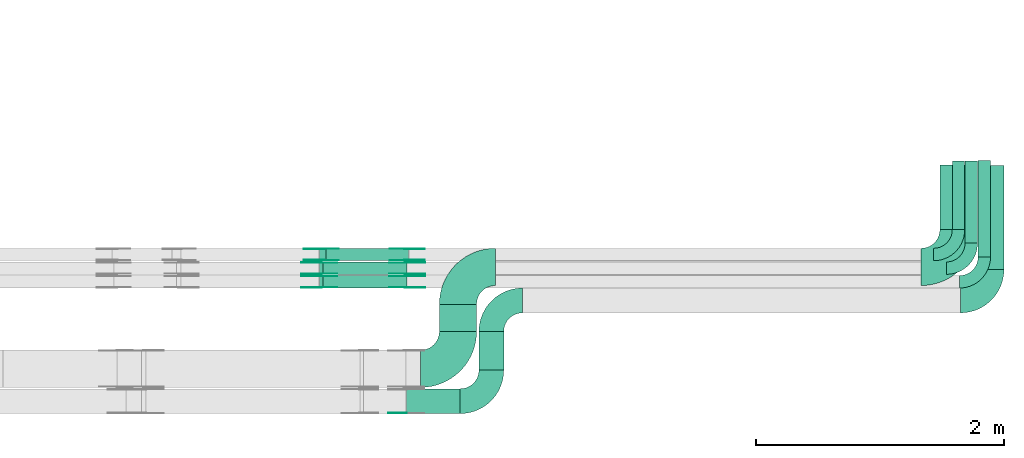
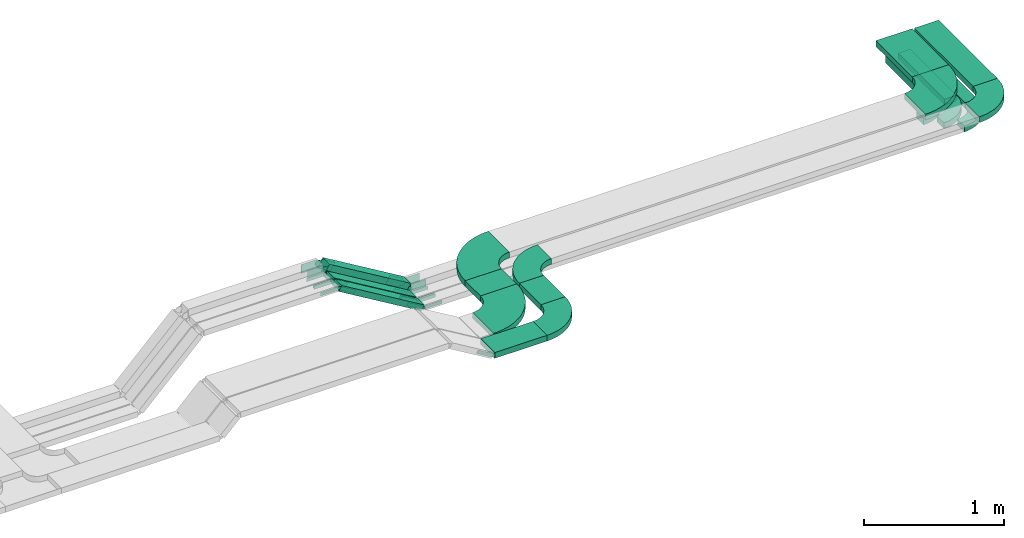
# One storey, part 18 of 19: 34 flow fittings, 11 flow segments.
"""IFC2X3 building model written with IfcOpenShell, lengths in millimetres."""

import ifcopenshell
import ifcopenshell.guid

model = None  # the IFC model being written
_history = None  # IfcOwnerHistory: only IFC2X3 demands one
_inside = {}  # id of a spatial element -> (the spatial element, [elements in it])
_under = {}  # id of a project, library or spatial element -> (it, [spatial elements below it])
_declared = {}  # id of a project -> (the project, [libraries it declares])
_typed = {}  # id of a type object -> (the type object, [elements of that type])
_made_of = {}  # id of a material, layer set ... -> (it, [elements and type objects made of it])


def new_model(schema):
    """Start an empty IFC model of exactly this schema.

    Asked for "IFC4X3", IfcOpenShell would pick the latest addendum, in which some entities
    have other attributes; the version numbers below select the first issue.
    IFC2X3 requires an IfcOwnerHistory on every rooted entity: one is made here for all.
    """
    global model, _history
    if schema == "IFC4X3":
        model = ifcopenshell.file(schema_version=(4, 3, 0, 0))
    else:
        model = ifcopenshell.file(schema=schema)
    _inside.clear()
    _under.clear()
    _declared.clear()
    _typed.clear()
    _made_of.clear()
    _history = None
    if model.schema == "IFC2X3":
        org = make("IfcOrganization", Name="unknown")
        user = make(
            "IfcPersonAndOrganization",
            ThePerson=make("IfcPerson", FamilyName="unknown"),
            TheOrganization=org,
        )
        app = make(
            "IfcApplication",
            ApplicationDeveloper=org,
            Version="unknown",
            ApplicationFullName="unknown",
            ApplicationIdentifier="unknown",
        )
        _history = make(
            "IfcOwnerHistory",
            OwningUser=user,
            OwningApplication=app,
            ChangeAction="ADDED",
            CreationDate=0,
        )
    return model


def make(cls, **values):
    """One entity of the class cls with the attributes given. An attribute that is None is left unset."""
    return model.create_entity(
        cls, **{name: value for name, value in values.items() if value is not None}
    )


def entity(cls, *values):
    """Any entity or typed value of the class cls, its attributes in the order of the schema. None: left unset."""
    e = model.create_entity(cls)
    for i, value in enumerate(values):
        if value is not None:
            e[i] = value
    return e


def rooted(cls, **values):
    """An entity with a GlobalId (a new one), such as an element, a storey or a relation."""
    return make(cls, GlobalId=ifcopenshell.guid.new(), OwnerHistory=_history, **values)


def si_unit(unit_type, name, prefix=None):
    """IfcSIUnit, for example si_unit("LENGTHUNIT", "METRE", prefix="MILLI")."""
    return make("IfcSIUnit", UnitType=unit_type, Prefix=prefix, Name=name)


def converted_unit(unit_type, name, factor, base, dimensions=None, offset=None):
    """IfcConversionBasedUnit, such as the inch: factor (a typed value) times the base unit."""
    return make(
        "IfcConversionBasedUnit"
        if offset is None
        else "IfcConversionBasedUnitWithOffset",
        ConversionOffset=offset,
        Dimensions=None
        if dimensions is None
        else entity("IfcDimensionalExponents", *dimensions),
        UnitType=unit_type,
        Name=name,
        ConversionFactor=make(
            "IfcMeasureWithUnit", ValueComponent=factor, UnitComponent=base
        ),
    )


def derived_unit(unit_type, elements):
    """IfcDerivedUnit: a product of units, each with its exponent."""
    return make(
        "IfcDerivedUnit",
        Elements=[
            make("IfcDerivedUnitElement", Unit=unit, Exponent=power)
            for unit, power in elements
        ],
        UnitType=unit_type,
    )


def assignment(units):
    """IfcUnitAssignment: the units of a project."""
    return None if units is None else make("IfcUnitAssignment", Units=units)


def point(xyz):
    """IfcCartesianPoint."""
    return None if xyz is None else make("IfcCartesianPoint", Coordinates=xyz)


def direction(xyz):
    """IfcDirection."""
    return None if xyz is None else make("IfcDirection", DirectionRatios=xyz)


def frame(location, z_axis=None, x_axis=None):
    """IfcAxis2Placement3D, a coordinate frame: its origin and axes. An axis left out is left unset."""
    return make(
        "IfcAxis2Placement3D",
        Location=point(location),
        Axis=direction(z_axis),
        RefDirection=direction(x_axis),
    )


def frame_2d(location, x_axis=None):
    """IfcAxis2Placement2D, a coordinate frame in the plane: its origin and x axis."""
    return make(
        "IfcAxis2Placement2D", Location=point(location), RefDirection=direction(x_axis)
    )


def origin():
    """The frame at (0, 0, 0) with its axes left unset."""
    return frame((0.0, 0.0, 0.0))


def origin_2d_with_axis():
    """The frame at (0, 0) in the plane with the x axis (1, 0) written out."""
    return frame_2d((0.0, 0.0), x_axis=(1.0, 0.0))


def place(relative_to, where):
    """IfcLocalPlacement: puts the frame where relative to a parent placement (None: the world)."""
    return make(
        "IfcLocalPlacement", PlacementRelTo=relative_to, RelativePlacement=where
    )


def context(
    kind, dimensions, precision=None, world=None, true_north=None, identifier=None
):
    """IfcGeometricRepresentationContext, for example the 3D "Model" context."""
    return make(
        "IfcGeometricRepresentationContext",
        ContextIdentifier=identifier,
        ContextType=kind,
        CoordinateSpaceDimension=dimensions,
        Precision=precision,
        WorldCoordinateSystem=world,
        TrueNorth=true_north,
    )


def subcontext(parent, identifier, kind, view, scale=None):
    """IfcGeometricRepresentationSubContext, for example "Body" below "Model"."""
    return make(
        "IfcGeometricRepresentationSubContext",
        ContextIdentifier=identifier,
        ContextType=kind,
        ParentContext=parent,
        TargetScale=scale,
        TargetView=view,
    )


def project(units=None, contexts=None):
    """IfcProject with its units and contexts."""
    return rooted(
        "IfcProject",
        Name="project",
        RepresentationContexts=contexts,
        UnitsInContext=assignment(units),
    )


def spatial(cls, under=None, at=None, **own):
    """A site, building, storey or space (cls), placed at a placement, below another one or the project."""
    s = rooted(cls, ObjectPlacement=at, **own)
    if under is not None:
        _under.setdefault(under.id(), (under, []))[1].append(s)
    return s


def polyline(points):
    """IfcPolyline through the points."""
    return make("IfcPolyline", Points=[point(p) for p in points])


def circle_curve(where, radius):
    """IfcCircle in the frame where."""
    return make("IfcCircle", Position=where, Radius=radius)


def parameter(value):
    """IfcParameterValue: where a trimmed curve begins or ends, as a parameter of its basis curve."""
    return model.create_entity("IfcParameterValue", value)


def trimmed(basis, trim1, trim2, sense, master):
    """IfcTrimmedCurve: the piece of a basis curve between two trims."""
    return make(
        "IfcTrimmedCurve",
        BasisCurve=basis,
        Trim1=trim1,
        Trim2=trim2,
        SenseAgreement=sense,
        MasterRepresentation=master,
    )


def segment(curve, same_sense, transition):
    """IfcCompositeCurveSegment."""
    return make(
        "IfcCompositeCurveSegment",
        Transition=transition,
        SameSense=same_sense,
        ParentCurve=curve,
    )


def composite_curve(segments, self_intersect=None):
    """IfcCompositeCurve: segments joined end to end."""
    return make("IfcCompositeCurve", Segments=segments, SelfIntersect=self_intersect)


def profile(cls, at=None, kind="AREA", **sizes):
    """A parametric profile (cls). Its sizes go by their IFC names, for example OverallWidth=200.0."""
    return make(cls, ProfileType=kind, Position=at, **sizes)


def rectangle(**sizes):
    """IfcRectangleProfileDef."""
    return profile("IfcRectangleProfileDef", **sizes)


def outline(outer, holes=None, kind="AREA"):
    """IfcArbitraryClosedProfileDef: a profile drawn as a closed curve; with holes, ...WithVoids."""
    if holes is None:
        return make("IfcArbitraryClosedProfileDef", ProfileType=kind, OuterCurve=outer)
    return make(
        "IfcArbitraryProfileDefWithVoids",
        ProfileType=kind,
        OuterCurve=outer,
        InnerCurves=holes,
    )


def extrude(swept, where, along, depth):
    """IfcExtrudedAreaSolid: the profile swept, set in the frame where, extruded along a direction by depth."""
    return make(
        "IfcExtrudedAreaSolid",
        SweptArea=swept,
        Position=where,
        ExtrudedDirection=direction(along),
        Depth=depth,
    )


def shape(context_of_items, identifier, shape_type, items):
    """IfcShapeRepresentation: the items that make up one representation, for example the "Body"."""
    return make(
        "IfcShapeRepresentation",
        ContextOfItems=context_of_items,
        RepresentationIdentifier=identifier,
        RepresentationType=shape_type,
        Items=items,
    )


def source(mapping_origin, context_of_items, identifier, shape_type, items):
    """IfcRepresentationMap: a shape defined once, which mapped items show again and again."""
    return make(
        "IfcRepresentationMap",
        MappingOrigin=mapping_origin,
        MappedRepresentation=shape(context_of_items, identifier, shape_type, items),
    )


def transform(
    local_origin,
    x_axis=None,
    y_axis=None,
    z_axis=None,
    scale=None,
    scale2=None,
    scale3=None,
    uniform=True,
):
    """IfcCartesianTransformationOperator3D, or its non-uniform kind. x_axis, y_axis, z_axis: its Axis1, 2, 3."""
    if uniform:
        return make(
            "IfcCartesianTransformationOperator3D",
            Axis1=direction(x_axis),
            Axis2=direction(y_axis),
            LocalOrigin=point(local_origin),
            Scale=scale,
            Axis3=direction(z_axis),
        )
    return make(
        "IfcCartesianTransformationOperator3DnonUniform",
        Axis1=direction(x_axis),
        Axis2=direction(y_axis),
        LocalOrigin=point(local_origin),
        Scale=scale,
        Axis3=direction(z_axis),
        Scale2=scale2,
        Scale3=scale3,
    )


def mapped(mapping_source, mapping_target):
    """IfcMappedItem: shows the shape of a source again, moved by a transform."""
    return make(
        "IfcMappedItem", MappingSource=mapping_source, MappingTarget=mapping_target
    )


def material(Name=None, Category=None):
    """IfcMaterial."""
    return make("IfcMaterial", Name=Name, Category=Category)


def made_of(thing, what):
    """Note that an element or type object is made of a material, layer set ...; save() writes the relation."""
    if what is not None:
        _made_of.setdefault(what.id(), (what, []))[1].append(thing)
    return thing


def type_object(cls, material=None, **own):
    """A type object (cls), such as IfcWallType, which elements share."""
    return made_of(rooted(cls, **own), material)


def type_shapes(of_type, sources):
    """Give a type object the sources (RepresentationMaps) that its elements show as mapped items."""
    of_type.RepresentationMaps = sources


def element(
    cls,
    number,
    at=None,
    inside=None,
    cuts=None,
    type_object=None,
    material=None,
    context=None,
    identifier="Body",
    shape_type=None,
    held_by="IfcProductDefinitionShape",
    body=None,
    shapes=None,
    **own,
):
    """One element of the class cls, such as IfcWall. Its Tag is "e" and its number.

    at: its placement. inside: the storey or other place that contains it. cuts: it is an
    opening in that element (IfcRelVoidsElement). A single representation is given by context,
    identifier, shape_type and body (its items); several are given by shapes. held_by: the class
    of the entity that holds the representations. save() writes the other relations.
    """
    e = rooted(cls, Tag="e%d" % number, ObjectPlacement=at, **own)
    if body is not None:
        shapes = [shape(context, identifier, shape_type, body)]
    if shapes is not None:
        e.Representation = make(held_by, Representations=shapes)
    if inside is not None:
        _inside.setdefault(inside.id(), (inside, []))[1].append(e)
    if cuts is not None:
        rooted(
            "IfcRelVoidsElement", RelatingBuildingElement=cuts, RelatedOpeningElement=e
        )
    if type_object is not None:
        _typed.setdefault(type_object.id(), (type_object, []))[1].append(e)
    return made_of(e, material)


def aggregate(whole, parts):
    """IfcRelAggregates: a whole, such as a stair, and the parts it consists of."""
    return rooted("IfcRelAggregates", RelatingObject=whole, RelatedObjects=parts)


def save(model, path):
    """Write the relations noted so far, then the file.

    IfcRelAggregates (storeys below a building ...), IfcRelContainedInSpatialStructure (elements
    in a storey), IfcRelDefinesByType, IfcRelAssociatesMaterial and IfcRelDeclares: one each for
    every whole, place, type object, material and project.
    """
    for whole, parts in _under.values():
        aggregate(whole, parts)
    for where, things in _inside.values():
        rooted(
            "IfcRelContainedInSpatialStructure",
            RelatedElements=things,
            RelatingStructure=where,
        )
    for kind, things in _typed.values():
        rooted("IfcRelDefinesByType", RelatedObjects=things, RelatingType=kind)
    for what, things in _made_of.values():
        rooted("IfcRelAssociatesMaterial", RelatedObjects=things, RelatingMaterial=what)
    for by, libraries in _declared.values():
        rooted("IfcRelDeclares", RelatingContext=by, RelatedDefinitions=libraries)
    model.write(path)


model = new_model("IFC2X3")

# Units and contexts
model_context = context("Model", 3, precision=0.01, world=origin(), true_north=direction((6.12303176911189e-17, 1.0)))
body_context = subcontext(model_context, "Body", "Model", "MODEL_VIEW")
ifc_project = project(units=[si_unit("LENGTHUNIT", "METRE", prefix="MILLI"), si_unit("AREAUNIT", "SQUARE_METRE"), si_unit("VOLUMEUNIT", "CUBIC_METRE"), converted_unit("PLANEANGLEUNIT", "DEGREE", entity("IfcRatioMeasure", 0.0174532925199433), si_unit("PLANEANGLEUNIT", "RADIAN"), dimensions=[0, 0, 0, 0, 0, 0, 0]), si_unit("MASSUNIT", "GRAM", prefix="KILO"), derived_unit("MASSDENSITYUNIT", [(si_unit("MASSUNIT", "GRAM", prefix="KILO"), 1), (si_unit("LENGTHUNIT", "METRE"), -3)]), derived_unit("MOMENTOFINERTIAUNIT", [(si_unit("LENGTHUNIT", "METRE"), 4)]), si_unit("TIMEUNIT", "SECOND"), si_unit("FREQUENCYUNIT", "HERTZ"), si_unit("THERMODYNAMICTEMPERATUREUNIT", "DEGREE_CELSIUS"), derived_unit("THERMALTRANSMITTANCEUNIT", [(si_unit("MASSUNIT", "GRAM", prefix="KILO"), 1), (si_unit("THERMODYNAMICTEMPERATUREUNIT", "KELVIN"), -1), (si_unit("TIMEUNIT", "SECOND"), -3)]), derived_unit("VOLUMETRICFLOWRATEUNIT", [(si_unit("LENGTHUNIT", "METRE"), 3), (si_unit("TIMEUNIT", "SECOND"), -1)]), derived_unit("MASSFLOWRATEUNIT", [(si_unit("MASSUNIT", "GRAM", prefix="KILO"), 1), (si_unit("TIMEUNIT", "SECOND"), -1)]), derived_unit("ROTATIONALFREQUENCYUNIT", [(si_unit("TIMEUNIT", "SECOND"), -1)]), si_unit("ELECTRICCURRENTUNIT", "AMPERE"), si_unit("ELECTRICVOLTAGEUNIT", "VOLT"), si_unit("POWERUNIT", "WATT"), si_unit("FORCEUNIT", "NEWTON", prefix="KILO"), si_unit("ILLUMINANCEUNIT", "LUX"), si_unit("LUMINOUSFLUXUNIT", "LUMEN"), si_unit("LUMINOUSINTENSITYUNIT", "CANDELA"), derived_unit("USERDEFINED", [(si_unit("MASSUNIT", "GRAM", prefix="KILO"), -1), (si_unit("LENGTHUNIT", "METRE"), -2), (si_unit("TIMEUNIT", "SECOND"), 3), (si_unit("LUMINOUSFLUXUNIT", "LUMEN"), 1)]), derived_unit("LINEARVELOCITYUNIT", [(si_unit("LENGTHUNIT", "METRE"), 1), (si_unit("TIMEUNIT", "SECOND"), -1)]), si_unit("PRESSUREUNIT", "PASCAL"), derived_unit("USERDEFINED", [(si_unit("LENGTHUNIT", "METRE"), -2), (si_unit("MASSUNIT", "GRAM", prefix="KILO"), 1), (si_unit("TIMEUNIT", "SECOND"), -2)]), derived_unit("LINEARFORCEUNIT", [(si_unit("MASSUNIT", "GRAM", prefix="KILO"), 1), (si_unit("LENGTHUNIT", "METRE"), 1), (si_unit("TIMEUNIT", "SECOND"), -2), (si_unit("LENGTHUNIT", "METRE"), -1)]), derived_unit("PLANARFORCEUNIT", [(si_unit("MASSUNIT", "GRAM", prefix="KILO"), 1), (si_unit("LENGTHUNIT", "METRE"), 1), (si_unit("TIMEUNIT", "SECOND"), -2), (si_unit("LENGTHUNIT", "METRE"), -2)])], contexts=[model_context])

# Site, building, storey
site_placement = place(None, origin())
site = spatial("IfcSite", under=ifc_project, at=site_placement, CompositionType="ELEMENT")
building_placement = place(site_placement, origin())
building = spatial("IfcBuilding", under=site, at=building_placement, CompositionType="ELEMENT")
storey_placement = place(building_placement, frame((0.0, 0.0, 12000.0)))
storey = spatial("IfcBuildingStorey", under=building, at=storey_placement, CompositionType="ELEMENT", Elevation=12000.0)

# Flow segments
cable_carrier_segment_type = type_object("IfcCableCarrierSegmentType", PredefinedType="CABLETRAYSEGMENT")
flow_segment_1_placement = place(storey_placement, frame((68387.5, 10095.99, 2600.0)))
element("IfcFlowSegment", 1, at=flow_segment_1_placement, inside=storey, type_object=cable_carrier_segment_type, context=body_context, shape_type="SweptSolid", body=[
    extrude(rectangle(XDim=554.131964439549, YDim=99.9999999999946, at=origin_2d_with_axis()), frame((50.0, 277.07, 0.0), z_axis=(0.0, 0.0, 1.0), x_axis=(0.0, -1.0, 0.0)), (0.0, 0.0, 1.0), 99.9999999999989),
])
flow_segment_2_placement = place(storey_placement, frame((63291.75, 9844.99, 2615.26)))
element("IfcFlowSegment", 2, at=flow_segment_2_placement, inside=storey, type_object=cable_carrier_segment_type, context=body_context, shape_type="SweptSolid", body=[
    extrude(rectangle(XDim=100.000000000001, YDim=99.9999999999989, at=origin_2d_with_axis()), frame((25.67, 50.0, 441.56), z_axis=(0.85817092301159, 0.0, -0.513364068568727), x_axis=(0.513364068568727, 0.0, 0.85817092301159)), (0.0, 0.0, 1.0), 776.555579083693),
])
flow_segment_3_placement = place(storey_placement, frame((63291.75, 9734.99, 2608.17)))
element("IfcFlowSegment", 3, at=flow_segment_3_placement, inside=storey, type_object=cable_carrier_segment_type, context=body_context, shape_type="SweptSolid", body=[
    extrude(rectangle(XDim=49.9999999999925, YDim=99.9999999999989, at=origin_2d_with_axis()), frame((12.83, 50.0, 427.2), z_axis=(0.858170923011643, 0.0, -0.513364068568637), x_axis=(0.513364068568637, 0.0, 0.858170923011643)), (0.0, 0.0, 1.0), 790.369272490984),
])
flow_segment_4_placement = place(storey_placement, frame((68490.25, 9985.99, 2600.0)))
element("IfcFlowSegment", 4, at=flow_segment_4_placement, inside=storey, type_object=cable_carrier_segment_type, context=body_context, shape_type="SweptSolid", body=[
    extrude(rectangle(XDim=664.131964439559, YDim=99.9999999999946, at=origin_2d_with_axis()), frame((50.0, 332.07, 0.0), z_axis=(0.0, 0.0, 1.0), x_axis=(0.0, 1.0, 0.0)), (0.0, 0.0, 1.0), 50.0000000000038),
])
flow_segment_5_placement = place(storey_placement, frame((63291.75, 9624.99, 2608.17)))
element("IfcFlowSegment", 5, at=flow_segment_5_placement, inside=storey, type_object=cable_carrier_segment_type, context=body_context, shape_type="SweptSolid", body=[
    extrude(rectangle(XDim=49.9999999999962, YDim=99.9999999999989, at=origin_2d_with_axis()), frame((12.83, 50.0, 427.2), z_axis=(0.858170923011666, 0.0, -0.513364068568599), x_axis=(0.513364068568599, 0.0, 0.858170923011666)), (0.0, 0.0, 1.0), 790.369272491001),
])
flow_segment_6_placement = place(storey_placement, frame((68595.21, 9875.99, 2600.0)))
element("IfcFlowSegment", 6, at=flow_segment_6_placement, inside=storey, type_object=cable_carrier_segment_type, context=body_context, shape_type="SweptSolid", body=[
    extrude(rectangle(XDim=774.442563315416, YDim=99.9999999999946, at=origin_2d_with_axis()), frame((50.0, 387.22, 0.0), z_axis=(0.0, 0.0, 1.0), x_axis=(0.0, 1.0, 0.0)), (0.0, 0.0, 1.0), 50.0000000000038),
])
flow_segment_7_placement = place(storey_placement, frame((68287.5, 10095.99, 2800.0)))
element("IfcFlowSegment", 7, at=flow_segment_7_placement, inside=storey, type_object=cable_carrier_segment_type, context=body_context, shape_type="SweptSolid", body=[
    extrude(rectangle(XDim=518.999999999975, YDim=300.000000000001, at=origin_2d_with_axis()), frame((150.0, 259.5, 0.0), z_axis=(0.0, 0.0, 1.0), x_axis=(0.0, 1.0, 0.0)), (0.0, 0.0, 1.0), 49.9999999999995),
])
flow_segment_8_placement = place(storey_placement, frame((68603.95, 9775.99, 2800.0)))
element("IfcFlowSegment", 8, at=flow_segment_8_placement, inside=storey, type_object=cable_carrier_segment_type, context=body_context, shape_type="SweptSolid", body=[
    extrude(rectangle(XDim=837.829364585167, YDim=200.000000000007, at=origin_2d_with_axis()), frame((100.0, 418.91, 0.0), z_axis=(0.0, 0.0, 1.0), x_axis=(0.0, 1.0, 0.0)), (0.0, 0.0, 1.0), 50.0000000000016),
])
flow_segment_9_placement = place(storey_placement, frame((64256.44, 9275.99, 2800.0)))
element("IfcFlowSegment", 9, at=flow_segment_9_placement, inside=storey, type_object=cable_carrier_segment_type, context=body_context, shape_type="SweptSolid", body=[
    extrude(rectangle(XDim=218.000000000032, YDim=300.000000000001, at=origin_2d_with_axis()), frame((150.0, 109.0, 0.0), z_axis=(0.0, 0.0, 1.0), x_axis=(0.0, 1.0, 0.0)), (0.0, 0.0, 1.0), 50.0000000000016),
])
flow_segment_10_placement = place(storey_placement, frame((63992.02, 8613.82, 2800.0)))
element("IfcFlowSegment", 10, at=flow_segment_10_placement, inside=storey, type_object=cable_carrier_segment_type, context=body_context, shape_type="SweptSolid", body=[
    extrude(rectangle(XDim=432.202301983457, YDim=200.0, at=origin_2d_with_axis()), frame((216.1, 100.0, 0.0)), (0.0, 0.0, 1.0), 50.0000000000016),
])
flow_segment_11_placement = place(storey_placement, frame((64575.23, 8964.82, 2800.0)))
element("IfcFlowSegment", 11, at=flow_segment_11_placement, inside=storey, type_object=cable_carrier_segment_type, context=body_context, shape_type="SweptSolid", body=[
    extrude(rectangle(XDim=309.170635414788, YDim=200.000000000007, at=origin_2d_with_axis()), frame((100.0, 154.59, 0.0), z_axis=(0.0, 0.0, 1.0), x_axis=(0.0, -1.0, 0.0)), (0.0, 0.0, 1.0), 50.0000000000016),
])

# Flow fittings
ifc_material_1 = material()
cable_carrier_fitting_type_1 = type_object("IfcCableCarrierFittingType", Name="470_DKC_S5_Variable Angle Elbow 0-45:-", PredefinedType="NOTDEFINED", material=ifc_material_1)
shared_shape_1 = source(origin(), body_context, "Body", "SweptSolid", [
    extrude(outline(composite_curve([segment(polyline([(-150.75, -300.25), (-149.75, -300.25)]), True, "CONTINUOUS"), segment(trimmed(circle_curve(frame_2d((-149.75, 149.75), x_axis=(0.0, -1.0)), 450.0), [parameter(0.0)], [parameter(90.0000000000001)], True, "PARAMETER"), True, "CONTINUOUS"), segment(polyline([(300.25, 149.75), (300.25, 150.75)]), True, "CONTINUOUS"), segment(polyline([(300.25, 150.75), (0.25, 150.75)]), True, "CONTINUOUS"), segment(polyline([(0.25, 150.75), (0.25, 149.75)]), True, "CONTINUOUS"), segment(trimmed(circle_curve(frame_2d((-149.75, 149.75), x_axis=(0.0, -1.0)), 150.0), [parameter(0.0)], [parameter(90.0000000000001)], True, "PARAMETER"), False, "CONTINUOUS"), segment(polyline([(-149.75, -0.25), (-150.75, -0.25)]), True, "CONTINUOUS"), segment(polyline([(-150.75, -0.25), (-150.75, -300.25)]), True, "CONTINUOUS")], self_intersect=False)), frame((-150.25, 150.25, -25.0)), (0.0, 0.0, 1.0), 49.9999999999974),
])
type_shapes(cable_carrier_fitting_type_1, [shared_shape_1])
for number, where, name in (
    (12, (64406.44, 8974.99, 2825.0), "470_DKC_S5_Variable Angle Elbow 0-45:-"),
    (13, (68437.5, 9794.99, 2825.0), "470_DKC_S5_Variable Angle Elbow 0-45:-"),
):
    element("IfcFlowFitting", number, at=place(storey_placement, frame(where)), inside=storey, type_object=cable_carrier_fitting_type_1, material=ifc_material_1, Name=name, ObjectType="470_DKC_S5_Variable Angle Elbow 0-45:-", context=body_context, shape_type="MappedRepresentation", body=[
        mapped(shared_shape_1, transform((0.0, 0.0, 0.0), scale=1.0)),
    ])
flow_fitting_1_placement = place(storey_placement, frame((64406.44, 9794.99, 2825.0), z_axis=(0.0, 0.0, 1.0), x_axis=(-1.0, 0.0, 0.0)))
element("IfcFlowFitting", 14, at=flow_fitting_1_placement, inside=storey, type_object=cable_carrier_fitting_type_1, material=ifc_material_1, Name="470_DKC_S5_Variable Angle Elbow 0-45:-", ObjectType="470_DKC_S5_Variable Angle Elbow 0-45:-", context=body_context, shape_type="MappedRepresentation", body=[
    mapped(shared_shape_1, transform((0.0, 0.0, 0.0), scale=1.0)),
])
cable_carrier_fitting_type_2 = type_object("IfcCableCarrierFittingType", Name="470_DKC_S5_Variable Angle Elbow 0-45:-", PredefinedType="NOTDEFINED", material=ifc_material_1)
shared_shape_2 = source(origin(), body_context, "Body", "SweptSolid", [
    extrude(outline(composite_curve([segment(polyline([(-100.75, -150.25), (-99.75, -150.25)]), True, "CONTINUOUS"), segment(trimmed(circle_curve(frame_2d((-99.75, 99.75), x_axis=(0.0, -1.0)), 250.0), [parameter(0.0)], [parameter(90.0000000000001)], True, "PARAMETER"), True, "CONTINUOUS"), segment(polyline([(150.25, 99.75), (150.25, 100.75)]), True, "CONTINUOUS"), segment(polyline([(150.25, 100.75), (50.25, 100.75)]), True, "CONTINUOUS"), segment(polyline([(50.25, 100.75), (50.25, 99.75)]), True, "CONTINUOUS"), segment(trimmed(circle_curve(frame_2d((-99.75, 99.75), x_axis=(0.0, -1.0)), 150.0), [parameter(0.0)], [parameter(90.0000000000001)], True, "PARAMETER"), False, "CONTINUOUS"), segment(polyline([(-99.75, -50.25), (-100.75, -50.25)]), True, "CONTINUOUS"), segment(polyline([(-100.75, -50.25), (-100.75, -150.25)]), True, "CONTINUOUS")], self_intersect=False)), frame((-100.25, 100.25, -25.0)), (0.0, 0.0, 1.0), 49.9999999999997),
])
type_shapes(cable_carrier_fitting_type_2, [shared_shape_2])
for number, where, name in (
    (15, (68540.25, 9784.99, 2625.0), "470_DKC_S5_Variable Angle Elbow 0-45:-"),
    (16, (68645.21, 9674.99, 2625.0), "470_DKC_S5_Variable Angle Elbow 0-45:-"),
):
    element("IfcFlowFitting", number, at=place(storey_placement, frame(where)), inside=storey, type_object=cable_carrier_fitting_type_2, material=ifc_material_1, Name=name, ObjectType="470_DKC_S5_Variable Angle Elbow 0-45:-", context=body_context, shape_type="MappedRepresentation", body=[
        mapped(shared_shape_2, transform((0.0, 0.0, 0.0), scale=1.0)),
    ])
ifc_material_2 = material(Name="G")
cable_carrier_fitting_type_3 = type_object("IfcCableCarrierFittingType", PredefinedType="NOTDEFINED", material=ifc_material_2)
shared_shape_3 = source(origin(), body_context, "Body", "SweptSolid", [
    extrude(outline(composite_curve([segment(trimmed(circle_curve(frame_2d((-44.59, 0.0), x_axis=(1.0, 0.0)), 12.5), [parameter(90.0000000000007)], [parameter(270.0)], True, "PARAMETER"), True, "CONTINUOUS"), segment(polyline([(-44.59, -12.5), (-33.09, -12.5)]), True, "CONTINUOUS"), segment(polyline([(-33.09, -12.5), (-31.23, -14.5)]), True, "CONTINUOUS"), segment(polyline([(-31.23, -14.5), (108.91, -14.5)]), True, "CONTINUOUS"), segment(polyline([(108.91, -14.5), (108.91, 14.5)]), True, "CONTINUOUS"), segment(polyline([(108.91, 14.5), (-31.23, 14.5)]), True, "CONTINUOUS"), segment(polyline([(-31.23, 14.5), (-33.09, 12.5)]), True, "CONTINUOUS"), segment(polyline([(-33.09, 12.5), (-44.59, 12.5)]), True, "CONTINUOUS")], self_intersect=False)), frame((44.59, 0.0, 0.0), z_axis=(0.0, 0.0, -1.0), x_axis=(1.0, 0.0, 0.0)), (0.0, 0.0, -1.0), 2.0),
])
type_shapes(cable_carrier_fitting_type_3, [shared_shape_3])
flow_fitting_2_placement = place(storey_placement, frame((63296.85, 9739.53, 3040.0), z_axis=(0.0, -1.0, 0.0), x_axis=(-1.0, 0.0, 0.0)))
element("IfcFlowFitting", 17, at=flow_fitting_2_placement, inside=storey, type_object=cable_carrier_fitting_type_3, material=ifc_material_2, context=body_context, shape_type="MappedRepresentation", body=[
    mapped(shared_shape_3, transform((0.0, 0.0, 0.0), scale=1.0)),
])
cable_carrier_fitting_type_4 = type_object("IfcCableCarrierFittingType", PredefinedType="NOTDEFINED", material=ifc_material_2)
type_shapes(cable_carrier_fitting_type_4, [shared_shape_3])
flow_fitting_3_placement = place(storey_placement, frame((63296.85, 9828.45, 3040.0), z_axis=(0.0, 1.0, 0.0), x_axis=(0.858170923011632, 0.0, -0.513364068568655)))
element("IfcFlowFitting", 18, at=flow_fitting_3_placement, inside=storey, type_object=cable_carrier_fitting_type_4, material=ifc_material_2, context=body_context, shape_type="MappedRepresentation", body=[
    mapped(shared_shape_3, transform((0.0, 0.0, 0.0), scale=1.0)),
])
flow_fitting_4_placement = place(storey_placement, frame((63990.59, 9739.53, 2625.0), z_axis=(0.0, -1.0, 0.0), x_axis=(1.0, 0.0, 0.0)))
element("IfcFlowFitting", 19, at=flow_fitting_4_placement, inside=storey, type_object=cable_carrier_fitting_type_3, material=ifc_material_2, context=body_context, shape_type="MappedRepresentation", body=[
    mapped(shared_shape_3, transform((0.0, 0.0, 0.0), scale=1.0)),
])
flow_fitting_5_placement = place(storey_placement, frame((63990.59, 9828.45, 2625.0), z_axis=(0.0, 1.0, 0.0), x_axis=(-0.858170923011639, 0.0, 0.513364068568644)))
element("IfcFlowFitting", 20, at=flow_fitting_5_placement, inside=storey, type_object=cable_carrier_fitting_type_4, material=ifc_material_2, context=body_context, shape_type="MappedRepresentation", body=[
    mapped(shared_shape_3, transform((0.0, 0.0, 0.0), scale=1.0)),
])
flow_fitting_6_placement = place(storey_placement, frame((63990.59, 9629.53, 2625.0), z_axis=(0.0, -1.0, 0.0), x_axis=(1.0, 0.0, 0.0)))
element("IfcFlowFitting", 21, at=flow_fitting_6_placement, inside=storey, type_object=cable_carrier_fitting_type_3, material=ifc_material_2, context=body_context, shape_type="MappedRepresentation", body=[
    mapped(shared_shape_3, transform((0.0, 0.0, 0.0), scale=1.0)),
])
flow_fitting_7_placement = place(storey_placement, frame((63990.59, 9718.45, 2625.0), z_axis=(0.0, 1.0, 0.0), x_axis=(-0.858170923011646, 0.0, 0.513364068568632)))
element("IfcFlowFitting", 22, at=flow_fitting_7_placement, inside=storey, type_object=cable_carrier_fitting_type_4, material=ifc_material_2, context=body_context, shape_type="MappedRepresentation", body=[
    mapped(shared_shape_3, transform((0.0, 0.0, 0.0), scale=1.0)),
])
flow_fitting_8_placement = place(storey_placement, frame((63296.85, 9629.53, 3040.0), z_axis=(0.0, -1.0, 0.0), x_axis=(-1.0, 0.0, 0.0)))
element("IfcFlowFitting", 23, at=flow_fitting_8_placement, inside=storey, type_object=cable_carrier_fitting_type_3, material=ifc_material_2, context=body_context, shape_type="MappedRepresentation", body=[
    mapped(shared_shape_3, transform((0.0, 0.0, 0.0), scale=1.0)),
])
flow_fitting_9_placement = place(storey_placement, frame((63296.85, 9718.45, 3040.0), z_axis=(0.0, 1.0, 0.0), x_axis=(0.858170923011648, 0.0, -0.51336406856863)))
element("IfcFlowFitting", 24, at=flow_fitting_9_placement, inside=storey, type_object=cable_carrier_fitting_type_4, material=ifc_material_2, context=body_context, shape_type="MappedRepresentation", body=[
    mapped(shared_shape_3, transform((0.0, 0.0, 0.0), scale=1.0)),
])
cable_carrier_fitting_type_5 = type_object("IfcCableCarrierFittingType", PredefinedType="NOTDEFINED", material=ifc_material_2)
shared_shape_4 = source(origin(), body_context, "Body", "SweptSolid", [
    extrude(outline(composite_curve([segment(trimmed(circle_curve(frame_2d((-44.59, 0.0), x_axis=(1.0, 0.0)), 12.5), [parameter(90.0000000000007)], [parameter(270.0)], True, "PARAMETER"), True, "CONTINUOUS"), segment(polyline([(-44.59, -12.5), (-33.09, -12.5)]), True, "CONTINUOUS"), segment(polyline([(-33.09, -12.5), (-31.23, -14.5)]), True, "CONTINUOUS"), segment(polyline([(-31.23, -14.5), (108.91, -14.5)]), True, "CONTINUOUS"), segment(polyline([(108.91, -14.5), (108.91, 14.5)]), True, "CONTINUOUS"), segment(polyline([(108.91, 14.5), (-31.23, 14.5)]), True, "CONTINUOUS"), segment(polyline([(-31.23, 14.5), (-33.09, 12.5)]), True, "CONTINUOUS"), segment(polyline([(-33.09, 12.5), (-44.59, 12.5)]), True, "CONTINUOUS")], self_intersect=False)), frame((44.59, 0.0, 0.0)), (0.0, 0.0, 1.0), 2.0),
])
type_shapes(cable_carrier_fitting_type_5, [shared_shape_4])
flow_fitting_10_placement = place(storey_placement, frame((63296.85, 9830.45, 3040.0), z_axis=(0.0, 1.0, 0.0), x_axis=(-1.0, 0.0, 0.0)))
element("IfcFlowFitting", 25, at=flow_fitting_10_placement, inside=storey, type_object=cable_carrier_fitting_type_5, material=ifc_material_2, context=body_context, shape_type="MappedRepresentation", body=[
    mapped(shared_shape_4, transform((0.0, 0.0, 0.0), scale=1.0)),
])
cable_carrier_fitting_type_6 = type_object("IfcCableCarrierFittingType", PredefinedType="NOTDEFINED", material=ifc_material_2)
type_shapes(cable_carrier_fitting_type_6, [shared_shape_4])
flow_fitting_11_placement = place(storey_placement, frame((63296.85, 9741.53, 3040.0), z_axis=(0.0, -1.0, 0.0), x_axis=(0.858170923011632, 0.0, -0.513364068568655)))
element("IfcFlowFitting", 26, at=flow_fitting_11_placement, inside=storey, type_object=cable_carrier_fitting_type_6, material=ifc_material_2, context=body_context, shape_type="MappedRepresentation", body=[
    mapped(shared_shape_4, transform((0.0, 0.0, 0.0), scale=1.0)),
])
flow_fitting_12_placement = place(storey_placement, frame((63990.59, 9830.45, 2625.0), z_axis=(0.0, 1.0, 0.0), x_axis=(1.0, 0.0, 0.0)))
element("IfcFlowFitting", 27, at=flow_fitting_12_placement, inside=storey, type_object=cable_carrier_fitting_type_5, material=ifc_material_2, context=body_context, shape_type="MappedRepresentation", body=[
    mapped(shared_shape_4, transform((0.0, 0.0, 0.0), scale=1.0)),
])
flow_fitting_13_placement = place(storey_placement, frame((63990.59, 9741.53, 2625.0), z_axis=(0.0, -1.0, 0.0), x_axis=(-0.858170923011639, 0.0, 0.513364068568644)))
element("IfcFlowFitting", 28, at=flow_fitting_13_placement, inside=storey, type_object=cable_carrier_fitting_type_6, material=ifc_material_2, context=body_context, shape_type="MappedRepresentation", body=[
    mapped(shared_shape_4, transform((0.0, 0.0, 0.0), scale=1.0)),
])
flow_fitting_14_placement = place(storey_placement, frame((63990.59, 9720.45, 2625.0), z_axis=(0.0, 1.0, 0.0), x_axis=(1.0, 0.0, 0.0)))
element("IfcFlowFitting", 29, at=flow_fitting_14_placement, inside=storey, type_object=cable_carrier_fitting_type_5, material=ifc_material_2, context=body_context, shape_type="MappedRepresentation", body=[
    mapped(shared_shape_4, transform((0.0, 0.0, 0.0), scale=1.0)),
])
flow_fitting_15_placement = place(storey_placement, frame((63990.59, 9631.53, 2625.0), z_axis=(0.0, -1.0, 0.0), x_axis=(-0.858170923011646, 0.0, 0.513364068568632)))
element("IfcFlowFitting", 30, at=flow_fitting_15_placement, inside=storey, type_object=cable_carrier_fitting_type_6, material=ifc_material_2, context=body_context, shape_type="MappedRepresentation", body=[
    mapped(shared_shape_4, transform((0.0, 0.0, 0.0), scale=1.0)),
])
flow_fitting_16_placement = place(storey_placement, frame((63296.85, 9720.45, 3040.0), z_axis=(0.0, 1.0, 0.0), x_axis=(-1.0, 0.0, 0.0)))
element("IfcFlowFitting", 31, at=flow_fitting_16_placement, inside=storey, type_object=cable_carrier_fitting_type_5, material=ifc_material_2, context=body_context, shape_type="MappedRepresentation", body=[
    mapped(shared_shape_4, transform((0.0, 0.0, 0.0), scale=1.0)),
])
for number, where, z_axis, x_axis in (
    (32, (63296.85, 9631.53, 3040.0), (0.0, -1.0, 0.0), (0.858170923011648, 0.0, -0.51336406856863)),
    (33, (63983.01, 8620.36, 2825.0), (0.0, -1.0, 0.0), (-0.858170923011649, 0.0, 0.513364068568627)),
):
    element("IfcFlowFitting", number, at=place(storey_placement, frame(where, z_axis=z_axis, x_axis=x_axis)), inside=storey, type_object=cable_carrier_fitting_type_6, material=ifc_material_2, context=body_context, shape_type="MappedRepresentation", body=[
        mapped(shared_shape_4, transform((0.0, 0.0, 0.0), scale=1.0)),
    ])
cable_carrier_fitting_type_7 = type_object("IfcCableCarrierFittingType", Name="470_DKC_S5_Variable Angle Elbow 0-45:-", PredefinedType="NOTDEFINED", material=ifc_material_1)
shared_shape_5 = source(origin(), body_context, "Body", "SweptSolid", [
    extrude(outline(composite_curve([segment(polyline([(-100.75, -150.25), (-99.75, -150.25)]), True, "CONTINUOUS"), segment(trimmed(circle_curve(frame_2d((-99.75, 99.75), x_axis=(0.0, -1.0)), 250.0), [parameter(0.0)], [parameter(90.0000000000001)], True, "PARAMETER"), True, "CONTINUOUS"), segment(polyline([(150.25, 99.75), (150.25, 100.75)]), True, "CONTINUOUS"), segment(polyline([(150.25, 100.75), (50.25, 100.75)]), True, "CONTINUOUS"), segment(polyline([(50.25, 100.75), (50.25, 99.75)]), True, "CONTINUOUS"), segment(trimmed(circle_curve(frame_2d((-99.75, 99.75), x_axis=(0.0, -1.0)), 150.0), [parameter(0.0)], [parameter(90.0000000000001)], True, "PARAMETER"), False, "CONTINUOUS"), segment(polyline([(-99.75, -50.25), (-100.75, -50.25)]), True, "CONTINUOUS"), segment(polyline([(-100.75, -50.25), (-100.75, -150.25)]), True, "CONTINUOUS")], self_intersect=False)), frame((-100.25, 100.25, -50.0)), (0.0, 0.0, 1.0), 100.0),
])
type_shapes(cable_carrier_fitting_type_7, [shared_shape_5])
flow_fitting_17_placement = place(storey_placement, frame((68437.5, 9894.99, 2650.0)))
element("IfcFlowFitting", 34, at=flow_fitting_17_placement, inside=storey, type_object=cable_carrier_fitting_type_7, material=ifc_material_1, Name="470_DKC_S5_Variable Angle Elbow 0-45:-", ObjectType="470_DKC_S5_Variable Angle Elbow 0-45:-", context=body_context, shape_type="MappedRepresentation", body=[
    mapped(shared_shape_5, transform((0.0, 0.0, 0.0), scale=1.0)),
])
cable_carrier_fitting_type_8 = type_object("IfcCableCarrierFittingType", Name="470_DKC_S5_Variable Angle Elbow 0-45:-", PredefinedType="NOTDEFINED", material=ifc_material_1)
shared_shape_6 = source(origin(), body_context, "Body", "SweptSolid", [
    extrude(outline(composite_curve([segment(polyline([(-125.75, -225.25), (-124.75, -225.25)]), True, "CONTINUOUS"), segment(trimmed(circle_curve(frame_2d((-124.75, 124.75), x_axis=(0.0, -1.0)), 350.0), [parameter(0.0)], [parameter(90.0000000000001)], True, "PARAMETER"), True, "CONTINUOUS"), segment(polyline([(225.25, 124.75), (225.25, 125.75)]), True, "CONTINUOUS"), segment(polyline([(225.25, 125.75), (25.25, 125.75)]), True, "CONTINUOUS"), segment(polyline([(25.25, 125.75), (25.25, 124.75)]), True, "CONTINUOUS"), segment(trimmed(circle_curve(frame_2d((-124.75, 124.75), x_axis=(0.0, -1.0)), 150.0), [parameter(0.0)], [parameter(90.0000000000001)], True, "PARAMETER"), False, "CONTINUOUS"), segment(polyline([(-124.75, -25.25), (-125.75, -25.25)]), True, "CONTINUOUS"), segment(polyline([(-125.75, -25.25), (-125.75, -225.25)]), True, "CONTINUOUS")], self_intersect=False)), frame((-125.25, 125.25, -25.0)), (0.0, 0.0, 1.0), 50.000000000001),
])
type_shapes(cable_carrier_fitting_type_8, [shared_shape_6])
flow_fitting_18_placement = place(storey_placement, frame((68703.95, 9524.99, 2825.0)))
element("IfcFlowFitting", 35, at=flow_fitting_18_placement, inside=storey, type_object=cable_carrier_fitting_type_8, material=ifc_material_1, Name="470_DKC_S5_Variable Angle Elbow 0-45:-", ObjectType="470_DKC_S5_Variable Angle Elbow 0-45:-", context=body_context, shape_type="MappedRepresentation", body=[
    mapped(shared_shape_6, transform((0.0, 0.0, 0.0), scale=1.0)),
])
flow_fitting_19_placement = place(storey_placement, frame((64675.23, 9524.99, 2825.0), z_axis=(0.0, 0.0, 1.0), x_axis=(-1.0, 0.0, 0.0)))
element("IfcFlowFitting", 36, at=flow_fitting_19_placement, inside=storey, type_object=cable_carrier_fitting_type_8, material=ifc_material_1, Name="470_DKC_S5_Variable Angle Elbow 0-45:-", ObjectType="470_DKC_S5_Variable Angle Elbow 0-45:-", context=body_context, shape_type="MappedRepresentation", body=[
    mapped(shared_shape_6, transform((0.0, 0.0, 0.0), scale=1.0)),
])
flow_fitting_20_placement = place(storey_placement, frame((64675.23, 8713.82, 2825.0)))
element("IfcFlowFitting", 37, at=flow_fitting_20_placement, inside=storey, type_object=cable_carrier_fitting_type_8, material=ifc_material_1, Name="470_DKC_S5_Variable Angle Elbow 0-45:-", ObjectType="470_DKC_S5_Variable Angle Elbow 0-45:-", context=body_context, shape_type="MappedRepresentation", body=[
    mapped(shared_shape_6, transform((0.0, 0.0, 0.0), scale=1.0)),
])
cable_carrier_fitting_type_9 = type_object("IfcCableCarrierFittingType", PredefinedType="NOTDEFINED", material=ifc_material_2)
shared_shape_7 = source(origin(), body_context, "Body", "SweptSolid", [
    extrude(outline(composite_curve([segment(trimmed(circle_curve(frame_2d((-41.47, 0.0), x_axis=(1.0, 0.0)), 25.0), [parameter(90.0000000000007)], [parameter(270.0)], True, "PARAMETER"), True, "CONTINUOUS"), segment(polyline([(-41.47, -25.0), (-29.97, -25.0)]), True, "CONTINUOUS"), segment(polyline([(-29.97, -25.0), (-28.1, -38.5)]), True, "CONTINUOUS"), segment(polyline([(-28.1, -38.5), (99.53, -38.5)]), True, "CONTINUOUS"), segment(polyline([(99.53, -38.5), (99.53, 38.5)]), True, "CONTINUOUS"), segment(polyline([(99.53, 38.5), (-28.1, 38.5)]), True, "CONTINUOUS"), segment(polyline([(-28.1, 38.5), (-29.97, 25.0)]), True, "CONTINUOUS"), segment(polyline([(-29.97, 25.0), (-41.47, 25.0)]), True, "CONTINUOUS")], self_intersect=False)), frame((41.47, 0.0, 0.0), z_axis=(0.0, 0.0, -1.0), x_axis=(1.0, 0.0, 0.0)), (0.0, 0.0, -1.0), 2.0),
])
type_shapes(cable_carrier_fitting_type_9, [shared_shape_7])
flow_fitting_21_placement = place(storey_placement, frame((63997.5, 9940.45, 2650.0), z_axis=(0.0, 1.0, 0.0), x_axis=(-0.858170923011602, 0.0, 0.513364068568707)))
element("IfcFlowFitting", 38, at=flow_fitting_21_placement, inside=storey, type_object=cable_carrier_fitting_type_9, material=ifc_material_2, context=body_context, shape_type="MappedRepresentation", body=[
    mapped(shared_shape_7, transform((0.0, 0.0, 0.0), scale=1.0)),
])
cable_carrier_fitting_type_10 = type_object("IfcCableCarrierFittingType", PredefinedType="NOTDEFINED", material=ifc_material_2)
type_shapes(cable_carrier_fitting_type_10, [shared_shape_7])
flow_fitting_22_placement = place(storey_placement, frame((63997.5, 9851.53, 2650.0), z_axis=(0.0, -1.0, 0.0), x_axis=(1.0, 0.0, 0.0)))
element("IfcFlowFitting", 39, at=flow_fitting_22_placement, inside=storey, type_object=cable_carrier_fitting_type_10, material=ifc_material_2, context=body_context, shape_type="MappedRepresentation", body=[
    mapped(shared_shape_7, transform((0.0, 0.0, 0.0), scale=1.0)),
])
flow_fitting_23_placement = place(storey_placement, frame((63303.76, 9940.45, 3065.0), z_axis=(0.0, 1.0, 0.0), x_axis=(0.858170923011602, 0.0, -0.513364068568707)))
element("IfcFlowFitting", 40, at=flow_fitting_23_placement, inside=storey, type_object=cable_carrier_fitting_type_9, material=ifc_material_2, context=body_context, shape_type="MappedRepresentation", body=[
    mapped(shared_shape_7, transform((0.0, 0.0, 0.0), scale=1.0)),
])
flow_fitting_24_placement = place(storey_placement, frame((63303.76, 9851.53, 3065.0), z_axis=(0.0, -1.0, 0.0), x_axis=(-1.0, 0.0, 0.0)))
element("IfcFlowFitting", 41, at=flow_fitting_24_placement, inside=storey, type_object=cable_carrier_fitting_type_10, material=ifc_material_2, context=body_context, shape_type="MappedRepresentation", body=[
    mapped(shared_shape_7, transform((0.0, 0.0, 0.0), scale=1.0)),
])
cable_carrier_fitting_type_11 = type_object("IfcCableCarrierFittingType", PredefinedType="NOTDEFINED", material=ifc_material_2)
shared_shape_8 = source(origin(), body_context, "Body", "SweptSolid", [
    extrude(outline(composite_curve([segment(trimmed(circle_curve(frame_2d((-41.47, 0.0), x_axis=(1.0, 0.0)), 25.0), [parameter(90.0000000000007)], [parameter(270.0)], True, "PARAMETER"), True, "CONTINUOUS"), segment(polyline([(-41.47, -25.0), (-29.97, -25.0)]), True, "CONTINUOUS"), segment(polyline([(-29.97, -25.0), (-28.1, -38.5)]), True, "CONTINUOUS"), segment(polyline([(-28.1, -38.5), (99.53, -38.5)]), True, "CONTINUOUS"), segment(polyline([(99.53, -38.5), (99.53, 38.5)]), True, "CONTINUOUS"), segment(polyline([(99.53, 38.5), (-28.1, 38.5)]), True, "CONTINUOUS"), segment(polyline([(-28.1, 38.5), (-29.97, 25.0)]), True, "CONTINUOUS"), segment(polyline([(-29.97, 25.0), (-41.47, 25.0)]), True, "CONTINUOUS")], self_intersect=False)), frame((41.47, 0.0, 0.0)), (0.0, 0.0, 1.0), 2.0),
])
type_shapes(cable_carrier_fitting_type_11, [shared_shape_8])
flow_fitting_25_placement = place(storey_placement, frame((63997.5, 9849.53, 2650.0), z_axis=(0.0, -1.0, 0.0), x_axis=(-0.858170923011602, 0.0, 0.513364068568707)))
element("IfcFlowFitting", 42, at=flow_fitting_25_placement, inside=storey, type_object=cable_carrier_fitting_type_11, material=ifc_material_2, context=body_context, shape_type="MappedRepresentation", body=[
    mapped(shared_shape_8, transform((0.0, 0.0, 0.0), scale=1.0)),
])
cable_carrier_fitting_type_12 = type_object("IfcCableCarrierFittingType", PredefinedType="NOTDEFINED", material=ifc_material_2)
type_shapes(cable_carrier_fitting_type_12, [shared_shape_8])
flow_fitting_26_placement = place(storey_placement, frame((63997.5, 9938.45, 2650.0), z_axis=(0.0, 1.0, 0.0), x_axis=(1.0, 0.0, 0.0)))
element("IfcFlowFitting", 43, at=flow_fitting_26_placement, inside=storey, type_object=cable_carrier_fitting_type_12, material=ifc_material_2, context=body_context, shape_type="MappedRepresentation", body=[
    mapped(shared_shape_8, transform((0.0, 0.0, 0.0), scale=1.0)),
])
flow_fitting_27_placement = place(storey_placement, frame((63303.76, 9849.53, 3065.0), z_axis=(0.0, -1.0, 0.0), x_axis=(0.858170923011602, 0.0, -0.513364068568707)))
element("IfcFlowFitting", 44, at=flow_fitting_27_placement, inside=storey, type_object=cable_carrier_fitting_type_11, material=ifc_material_2, context=body_context, shape_type="MappedRepresentation", body=[
    mapped(shared_shape_8, transform((0.0, 0.0, 0.0), scale=1.0)),
])
flow_fitting_28_placement = place(storey_placement, frame((63303.76, 9938.45, 3065.0), z_axis=(0.0, 1.0, 0.0), x_axis=(-1.0, 0.0, 0.0)))
element("IfcFlowFitting", 45, at=flow_fitting_28_placement, inside=storey, type_object=cable_carrier_fitting_type_12, material=ifc_material_2, context=body_context, shape_type="MappedRepresentation", body=[
    mapped(shared_shape_8, transform((0.0, 0.0, 0.0), scale=1.0)),
])

save(model, "model.ifc")
